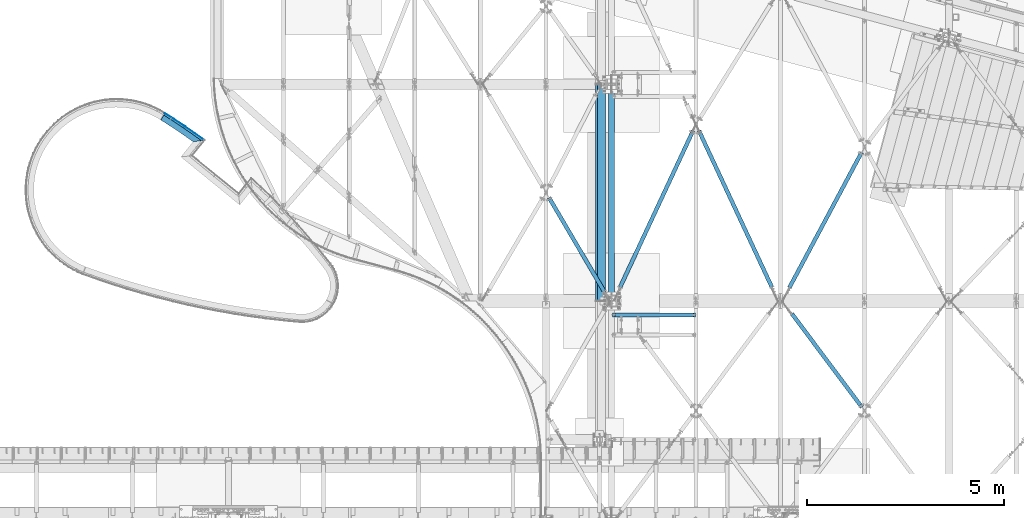
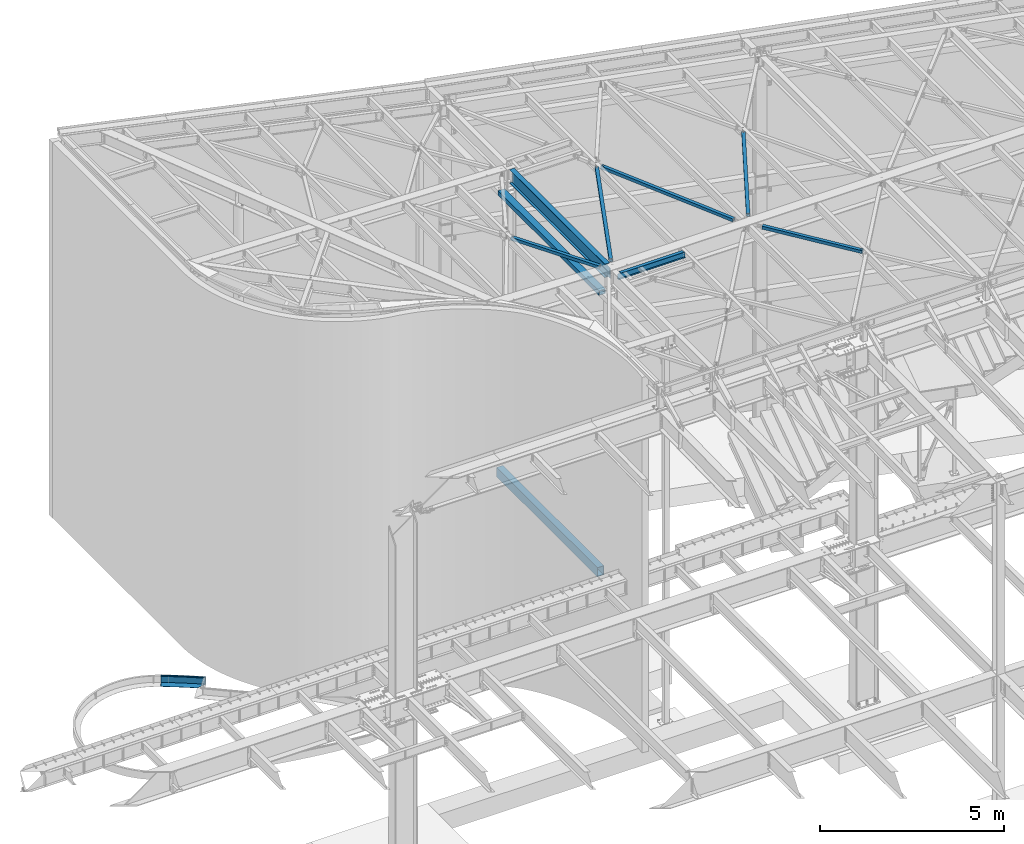
# One storey, part 1152 of 1763: 12 beams, 10 elements without a shape of their own.
"""IFC2X3 building model written with IfcOpenShell, lengths in millimetres."""

from ifc_helpers import new_model, si_unit, frame, origin_with_axes, place, context, subcontext, project, spatial, faceted_brep, material, type_object, element, aggregate, save


model = new_model("IFC2X3")

# Units and contexts
model_context = context("Model", 3, precision=1e-05, world=origin_with_axes())
body_context = subcontext(model_context, "Body", "Model", "MODEL_VIEW")
ifc_project = project(units=[si_unit("LENGTHUNIT", "METRE", prefix="MILLI"), si_unit("AREAUNIT", "SQUARE_METRE"), si_unit("VOLUMEUNIT", "CUBIC_METRE"), si_unit("MASSUNIT", "GRAM", prefix="KILO"), si_unit("TIMEUNIT", "SECOND"), si_unit("PLANEANGLEUNIT", "RADIAN"), si_unit("SOLIDANGLEUNIT", "STERADIAN"), si_unit("THERMODYNAMICTEMPERATUREUNIT", "DEGREE_CELSIUS"), si_unit("LUMINOUSINTENSITYUNIT", "LUMEN")], contexts=[model_context])

# Site, building, storey
site_placement = place(None, origin_with_axes())
site = spatial("IfcSite", under=ifc_project, at=site_placement, CompositionType="ELEMENT")
building_placement = place(site_placement, origin_with_axes())
building = spatial("IfcBuilding", under=site, at=building_placement, Name="Undefined", CompositionType="ELEMENT")
storey_placement = place(building_placement, origin_with_axes())
storey = spatial("IfcBuildingStorey", under=building, at=storey_placement, Name="Undefined", CompositionType="ELEMENT", Elevation=0.0)

# Assembly, beams
assembly_1_placement = place(storey_placement, origin_with_axes())
assembly_1 = element("IfcElementAssembly", 1, at=assembly_1_placement, inside=storey, Name="PLATE", AssemblyPlace="NOTDEFINED", PredefinedType="RIGID_FRAME")
ifc_material_1 = material(Name="STEEL/A36")
beam_type_1 = type_object("IfcBeamType", PredefinedType="NOTDEFINED")
beam_1_placement = place(assembly_1_placement, frame((-51077.3784696731, 62383.7207744882, -250.825), z_axis=(0.547466988136322, 0.836827280208374, 0.0), x_axis=(0.836827280208373, -0.547466988136323, 0.0)))
beam_1 = element("IfcBeam", 2, at=beam_1_placement, type_object=beam_type_1, material=ifc_material_1, Name="PLATE", context=body_context, shape_type="Brep", body=[
    faceted_brep([(10.0865417062741, -3.17500008743065, -98.3292617559418), (6.35000010509975, -3.17500000000001, 98.4852721513162), (4.17785486206412e-08, 7.03514331235056e-08, 98.425000000243), (3.73654162029561, -5.10336519710108e-08, -98.3895339072369), (306.165417216951, -3.17500000000001, 101.331023322218), (612.330834247987, -3.17500000000001, 98.4249848149957), (612.330834247987, 3.17500000000001, 98.4249848149957), (306.165417216951, 3.17500000000001, 101.331023322218), (910.914176975595, 3.17500000000001, -107.000216220062), (608.594282907827, 3.17500000000001, -98.389548907151), (306.165412335249, 3.17500000000001, -95.5189766782496), (3.73654162029561, 3.17500000000001, -98.3895339072369), (4.17785486206412e-08, 3.17500000000001, 98.425000000243), (918.3859283559, 3.17500000000001, 89.7079316322706), (1217.57690494547, 3.17500000000001, 75.4985236143766), (1000.12444440338, 3.17500000000001, -111.237058867246), (918.3859283559, -3.17500000000001, 89.7079316322706), (1217.57690494547, -3.17500000000001, 75.4985236143766), (1000.12444440338, -3.17500000000001, -111.237058867246), (910.914176975595, -3.17500000000001, -107.000216220062), (608.594282907827, -3.17500000000001, -98.389548907151), (306.165412335249, -3.17500000000001, -95.5189766782496)], [[[0, 1, 2, 3]], [[4, 5, 6, 7]], [[8, 9, 10, 11, 12, 7, 6, 13, 14, 15]], [[5, 16, 13, 6]], [[13, 16, 17, 14]], [[15, 14, 17, 18]], [[19, 8, 15, 18]], [[9, 8, 19, 20]], [[10, 9, 20, 21]], [[11, 10, 21, 0, 3]], [[12, 11, 3, 2]], [[4, 7, 12, 2, 1]], [[21, 20, 19, 18, 17, 16, 5, 4, 1, 0]]]),
])
beam_type_2 = type_object("IfcBeamType", PredefinedType="NOTDEFINED")
beam_2_placement = place(assembly_1_placement, frame((-51021.8582786004, 62468.8080613474, -130.175), z_axis=(0.0, 0.0, 1.0), x_axis=(0.836819061160634, -0.547479551105094, 0.0)))
beam_2 = element("IfcBeam", 3, at=beam_2_placement, type_object=beam_type_2, material=ifc_material_1, Name="PLATE", context=body_context, shape_type="Brep", body=[
    faceted_brep([(6.47143222697196, -3.11361448790922, 123.825), (0.0602430581202498, 0.000571752359974198, 123.825), (0.0602430581202498, 0.000571752359974198, -123.825), (6.47143208340276, -3.11359935612199, -123.825), (-9.89530235528946e-10, 3.17499999998108, -123.825), (-9.89530235528946e-10, 3.17499999998108, 123.825), (306.286084533931, 6.08102800932829, 123.825), (306.286084533931, 6.08102800932829, -123.825), (612.572169099585, 3.17500324017601, 123.825), (612.572169099585, 3.17500324017601, -123.825), (918.747974716418, -5.54202798683036, 123.825), (918.747974716418, -5.54202798683036, -123.825), (1224.703262111, -20.066927085416, 123.825), (1224.703262111, -20.066927085416, -123.825), (1217.68876182109, -26.0907867926398, -123.825), (1217.68876182109, -26.0907867926398, 123.825), (918.50704594914, -11.8874557367089, 123.825), (918.50704594914, -11.8874557367089, -123.825), (612.451683042105, -3.17385359468972, -123.825), (612.451683042105, -3.17385359468972, 123.825), (306.286084567517, -0.2689719906557, -123.825), (306.286084567517, -0.2689719906557, 123.825)], [[[0, 1, 2, 3]], [[4, 5, 6, 7]], [[6, 8, 9, 7]], [[8, 10, 11, 9]], [[11, 10, 12, 13]], [[14, 13, 12, 15]], [[16, 17, 14, 15]], [[18, 17, 16, 19]], [[20, 18, 19, 21]], [[20, 21, 0, 3]], [[4, 7, 9, 11, 13, 14, 17, 18, 20, 3, 2]], [[5, 4, 2, 1]], [[21, 19, 16, 15, 12, 10, 8, 6, 5, 1, 0]]]),
])
beam_type_3 = type_object("IfcBeamType", PredefinedType="NOTDEFINED")
beam_3_placement = place(assembly_1_placement, frame((-51035.7642591912, 62447.5528571891, -3.175), z_axis=(0.547479551105092, 0.836819061160635, 0.0), x_axis=(0.836819061160634, -0.547479551105094, 0.0)))
beam_3 = element("IfcBeam", 4, at=beam_3_placement, type_object=beam_type_3, material=ifc_material_1, Name="PLATE", context=body_context, shape_type="Brep", body=[
    faceted_brep([(7.43646361827268, 3.17500008958277, -28.5044431845636), (1.08437511292868, -1.43714595779443e-09, -28.5647115024767), (-8.84756445884705e-09, 9.69761293490023e-09, 28.5749999999134), (6.35080316626409, 3.175, 28.6352561226777), (611.487794574437, 3.175, -28.5647082737523), (916.579615803115, 3.175, -37.2508777357652), (916.579615803115, -3.175, -37.2508777357652), (611.487794574437, -3.175, -28.5647082737523), (1161.57250206512, 3.175, -48.8816522294146), (1161.57250206512, -3.175, -48.8816522294146), (306.286084526073, -3.175, 31.481028009257), (612.572169091756, -3.175, 28.575003240112), (612.572169091756, 3.175, 28.575003240112), (306.286084526073, 3.175, 31.481028009257), (918.747974708574, -3.175, 19.857972013102), (918.747974708574, 3.175, 19.857972013102), (1224.70326210315, -3.175, 5.33307291452002), (1224.70326210315, 3.175, 5.33307291452002), (-8.84756445884705e-09, -3.175, 28.5749999999134), (1.08437511292868, -3.175, -28.5647115024767), (306.286084828374, -3.175, -25.6689719905771), (306.286084828374, 3.175, -25.6689719905771)], [[[0, 1, 2, 3]], [[4, 5, 6, 7]], [[6, 5, 8, 9]], [[10, 11, 12, 13]], [[11, 14, 15, 12]], [[15, 14, 16, 17]], [[8, 17, 16, 9]], [[14, 11, 10, 18, 19, 20, 7, 6, 9, 16]], [[21, 4, 7, 20]], [[13, 12, 15, 17, 8, 5, 4, 21, 0, 3]], [[18, 10, 13, 3, 2]], [[19, 18, 2, 1]], [[21, 20, 19, 1, 0]]]),
])
aggregate(assembly_1, [beam_1, beam_2, beam_3])

# Assembly, beam
assembly_2_placement = place(storey_placement, origin_with_axes())
assembly_2 = element("IfcElementAssembly", 5, at=assembly_2_placement, inside=storey, Name="BEAM", AssemblyPlace="NOTDEFINED", PredefinedType="RIGID_FRAME")
ifc_material_2 = material(Name="STEEL/A992")
beam_type_4 = type_object("IfcBeamType", Name="W8X10", PredefinedType="NOTDEFINED")
beam_4_placement = place(assembly_2_placement, frame((-39672.2896174484, 57346.8499999993, 12345.9875), z_axis=(0.0, 0.0, 1.0), x_axis=(1.0, 0.0, 0.0)))
beam_4 = element("IfcBeam", 6, at=beam_4_placement, type_object=beam_type_4, material=ifc_material_2, Name="BEAM", ObjectType="W8X10", context=body_context, shape_type="Brep", body=[
    faceted_brep([(2073.27499999999, -50.8000000000029, 100.012500000001), (2073.27499999999, -50.8000000000029, 95.25), (2073.27499999999, -2.38124999999854, 95.25), (2073.27499999999, -2.38124999999854, 93.4024995803829), (2073.27499999999, 2.38124999999854, 93.4024995803829), (2073.27499999999, 2.38124999999854, 95.25), (2073.27499999999, 50.8000000000029, 95.25), (2073.27499999999, 50.8000000000029, 100.012500000001), (2074.24172992259, -2.38124999999854, 88.5424200623365), (2074.24172992259, 2.38124999999854, 88.5424200623365), (2076.99474382306, -2.38124999999854, 84.4222435941829), (2076.99474382306, 2.38124999999854, 84.4222435941829), (2081.11492029121, -2.38124999999854, 81.6692296937053), (2081.11492029121, 2.38124999999854, 81.6692296937053), (2085.97499980926, -2.38124999999854, 80.7024997711178), (2085.97499980926, 2.38124999999854, 80.7024997711178), (2124.075, -2.38124999999854, 80.7024997711178), (2124.075, 2.38124999999854, 80.7024997711178), (88.8999969557553, -50.8000000000029, 100.012500000001), (88.8999969557553, 50.8000000000029, 100.012500000001), (88.8999969557553, 50.8000000000029, 95.25), (88.8999969557553, 2.38124999999854, 95.25), (88.8999969557553, 2.38124999999854, 84.1374998092651), (88.8999969557553, -2.38124999999854, 84.1374998092651), (88.8999969557553, -2.38124999999854, 95.25), (88.8999969557553, -50.8000000000029, 95.25), (87.9332670331642, 2.38124999999854, 79.2774202912187), (87.9332670331642, -2.38124999999854, 79.2774202912187), (85.1802531326903, 2.38124999999854, 75.1572438230651), (85.1802531326903, -2.38124999999854, 75.1572438230651), (81.0600766645366, 2.38124999999854, 72.4042299225875), (81.0600766645366, -2.38124999999854, 72.4042299225875), (76.1999971464902, 2.38124999999854, 71.4375), (76.1999971464902, -2.38124999999854, 71.4375), (16.6687500075204, 2.38124999999854, 71.4375), (16.6687500075204, -2.38124999999854, 71.4375), (16.6687500075204, 2.38124999999854, -95.25), (16.6687500075204, 50.8000000000029, -95.25), (16.6687500075204, 50.8000000000029, -100.012500000001), (16.6687500075204, -50.8000000000029, -100.012500000001), (16.6687500075204, -50.8000000000029, -95.25), (16.6687500075204, -2.38124999999854, -95.25), (2124.075, 2.38124999999854, -95.25), (2124.075, 50.8000000000029, -95.25), (2124.075, 50.8000000000029, -100.012500000001), (2124.075, -50.8000000000029, -100.012500000001), (2124.075, -50.8000000000029, -95.25), (2124.075, -2.38124999999854, -95.25)], [[[0, 1, 2, 3, 4, 5, 6, 7]], [[8, 9, 4, 3]], [[10, 11, 9, 8]], [[12, 13, 11, 10]], [[14, 15, 13, 12]], [[16, 17, 15, 14]], [[18, 19, 20, 21, 22, 23, 24, 25]], [[23, 22, 26, 27]], [[27, 26, 28, 29]], [[29, 28, 30, 31]], [[31, 30, 32, 33]], [[33, 32, 34, 35]], [[36, 37, 38, 39, 40, 41, 35, 34]], [[37, 36, 42, 43]], [[38, 37, 43, 44]], [[39, 38, 44, 45]], [[40, 39, 45, 46]], [[41, 40, 46, 47]], [[12, 10, 8, 3, 2, 24, 23, 27, 29, 31, 33, 35, 41, 47, 16, 14]], [[25, 24, 2, 1]], [[18, 25, 1, 0]], [[19, 18, 0, 7]], [[20, 19, 7, 6]], [[21, 20, 6, 5]], [[42, 36, 34, 32, 30, 28, 26, 22, 21, 5, 4, 9, 11, 13, 15, 17]], [[47, 46, 45, 44, 43, 42, 17, 16]]]),
])
aggregate(assembly_2, [beam_4])

assembly_3_placement = place(storey_placement, origin_with_axes())
assembly_3 = element("IfcElementAssembly", 7, at=assembly_3_placement, inside=storey, Name="H. BRACE", AssemblyPlace="NOTDEFINED", PredefinedType="RIGID_FRAME")
ifc_material_3 = material()
beam_type_5 = type_object("IfcBeamType", Name="HSS4X4X3/8", PredefinedType="NOTDEFINED")
beam_5_placement = place(assembly_3_placement, frame((-37532.339615497, 62183.5045135885, 12371.3875), z_axis=(0.0, 0.0, 1.0), x_axis=(-0.422551801085181, -0.906338775182696, 0.0)))
beam_5 = element("IfcBeam", 8, at=beam_5_placement, type_object=beam_type_5, material=ifc_material_3, Name="H. BRACE", ObjectType="HSS4X4X3/8", context=body_context, shape_type="Brep", body=[
    faceted_brep([(176.586661769732, 6.34999856256309, 50.7999999999993), (176.586661769732, 6.34999856256309, 41.2749999999996), (254.374161510495, 6.35000155575017, 41.2749999999996), (254.374161510495, 6.35000155575017, 50.7999999999993), (254.374161999192, -6.34999844434515, 50.7999999999993), (254.374161999192, -6.34999844434515, 41.2749999999996), (176.586661741341, -6.35000143753587, 41.2749999999996), (176.586661741341, -6.35000143753587, 50.7999999999993), (176.586661769732, 6.34999856256309, -41.2749999999996), (176.586661769732, 6.34999856256309, -50.7999999999993), (254.374161510495, 6.35000155575017, -50.7999999999993), (254.374161510495, 6.35000155575017, -41.2749999999996), (254.374161999192, -6.34999844434515, -41.2749999999996), (254.374161999192, -6.34999844434515, -50.7999999999993), (176.586661741341, -6.35000143753587, -50.7999999999993), (176.586661741341, -6.35000143753587, -41.2749999999996), (176.586661663285, -41.275000000097, -41.2749999999996), (176.586661663285, -41.275000000097, 41.2749999999996), (4557.63064918239, -41.2750000071683, 41.2749999999996), (4557.63064918239, -41.2750000071683, -41.2749999999996), (176.586661869078, 50.8000000002348, -50.7999999999993), (4557.63064918239, 50.7999999927488, -50.7999999999993), (4557.63064918239, -50.8000000071625, -50.7999999999993), (176.586661641981, -50.8000000001239, -50.7999999999993), (176.586661641981, -50.8000000001239, 50.7999999999993), (4557.63064918239, -50.8000000071625, 50.7999999999993), (176.586661847788, 41.275000000197, 41.2749999999996), (4557.63064918239, 41.2749999927546, 41.2749999999996), (176.586661847788, 41.275000000197, -41.2749999999996), (4557.63064918239, 41.2749999927546, -41.2749999999996), (4557.63064918239, 50.7999999927488, 50.7999999999993), (176.586661869078, 50.8000000002348, 50.7999999999993)], [[[0, 1, 2, 3]], [[4, 5, 6, 7]], [[3, 2, 5, 4]], [[8, 9, 10, 11]], [[12, 13, 14, 15]], [[11, 10, 13, 12]], [[16, 17, 18, 19]], [[9, 20, 21, 22, 23, 14, 13, 10]], [[24, 23, 22, 25]], [[17, 16, 15, 14, 23, 24, 7, 6]], [[1, 26, 27, 18, 17, 6, 5, 2]], [[26, 28, 29, 27]], [[25, 22, 21, 30], [18, 27, 29, 19]], [[20, 31, 30, 21]], [[24, 25, 30, 31, 0, 3, 4, 7]], [[31, 20, 9, 8, 28, 26, 1, 0]], [[16, 19, 29, 28, 8, 11, 12, 15]]]),
])
aggregate(assembly_3, [beam_5])

assembly_4_placement = place(storey_placement, origin_with_axes())
assembly_4 = element("IfcElementAssembly", 9, at=assembly_4_placement, inside=storey, Name="H. BRACE", AssemblyPlace="NOTDEFINED", PredefinedType="RIGID_FRAME")
beam_6_placement = place(assembly_4_placement, frame((-33252.4396174507, 54913.6789185365, 12371.3875), z_axis=(0.0, 0.0, 1.0), x_axis=(-0.599553898754952, 0.800334381672896, 0.0)))
beam_6 = element("IfcBeam", 10, at=beam_6_placement, type_object=beam_type_5, material=ifc_material_3, Name="H. BRACE", ObjectType="HSS4X4X3/8", context=body_context, shape_type="Brep", body=[
    faceted_brep([(115.472498353723, 6.31029747364482, 50.7999999999993), (115.472498353723, 6.31029747364482, 41.2749999999996), (192.682016704122, 6.3102970257587, 41.2749999999996), (192.682016704122, 6.3102970257587, 50.7999999999993), (192.682016630453, -6.38970297431115, 50.7999999999993), (192.682016630453, -6.38970297431115, 41.2749999999996), (115.472498353723, -6.38970252641411, 41.2749999999996), (115.472498353723, -6.38970252641411, 50.7999999999993), (115.472498353723, 6.31029747364482, -41.2749999999996), (115.472498353723, 6.31029747364482, -50.7999999999993), (192.682016704122, 6.3102970257587, -50.7999999999993), (192.682016704122, 6.3102970257587, -41.2749999999996), (192.682016630453, -6.38970297431115, -41.2749999999996), (192.682016630453, -6.38970297431115, -50.7999999999993), (115.472498353723, -6.38970252641411, -50.7999999999993), (115.472498353723, -6.38970252641411, -41.2749999999996), (115.472498353723, -41.2750000001415, -41.2749999999996), (115.472498353723, -41.2750000001415, 41.2749999999996), (3071.36045602318, -41.2750000018805, 41.2749999999996), (3071.36045602318, -41.2750000018805, -41.2749999999996), (115.472498353723, 50.8000000000084, -50.7999999999993), (3071.36045602318, 50.7999999982621, -50.7999999999993), (3071.36045602318, -50.8000000018892, -50.7999999999993), (115.472498353723, -50.8000000001466, -50.7999999999993), (115.472498353723, -50.8000000001466, 50.7999999999993), (3071.36045602318, -50.8000000018892, 50.7999999999993), (115.472498353723, 41.2749999999924, 41.2749999999996), (3071.36045602318, 41.2749999982461, 41.2749999999996), (115.472498353723, 41.2749999999924, -41.2749999999996), (3071.36045602318, 41.2749999982461, -41.2749999999996), (3071.36045602318, 50.7999999982621, 50.7999999999993), (115.472498353723, 50.8000000000084, 50.7999999999993)], [[[0, 1, 2, 3]], [[4, 5, 6, 7]], [[3, 2, 5, 4]], [[8, 9, 10, 11]], [[12, 13, 14, 15]], [[11, 10, 13, 12]], [[16, 17, 18, 19]], [[9, 20, 21, 22, 23, 14, 13, 10]], [[24, 23, 22, 25]], [[17, 16, 15, 14, 23, 24, 7, 6]], [[1, 26, 27, 18, 17, 6, 5, 2]], [[26, 28, 29, 27]], [[25, 22, 21, 30], [18, 27, 29, 19]], [[20, 31, 30, 21]], [[24, 25, 30, 31, 0, 3, 4, 7]], [[31, 20, 9, 8, 28, 26, 1, 0]], [[16, 19, 29, 28, 8, 11, 12, 15]]]),
])
aggregate(assembly_4, [beam_6])

assembly_5_placement = place(storey_placement, origin_with_axes())
assembly_5 = element("IfcElementAssembly", 11, at=assembly_5_placement, inside=storey, Name="H. BRACE", AssemblyPlace="NOTDEFINED", PredefinedType="RIGID_FRAME")
beam_7_placement = place(assembly_5_placement, frame((-39723.089617434, 57702.4500000121, 12371.3875), z_axis=(0.0, 0.0, 1.0), x_axis=(-0.50652204411247, 0.862227011191441, 0.0)))
beam_7 = element("IfcBeam", 12, at=beam_7_placement, type_object=beam_type_5, material=ifc_material_3, Name="H. BRACE", ObjectType="HSS4X4X3/8", context=body_context, shape_type="Brep", body=[
    faceted_brep([(3046.4073382124, 6.34999999966658, 50.7999999999993), (2968.54605253917, 6.34999999969568, 50.7999999999993), (2968.54605253917, 6.34999999969568, 41.2749999999996), (3046.4073382124, 6.34999999966658, 41.2749999999996), (2968.54605253917, -6.35000000015589, 50.7999999999993), (2968.54605253917, -6.35000000015589, 41.2749999999996), (3046.4073382124, -6.35000000018135, 50.7999999999993), (3046.4073382124, -6.35000000018135, 41.2749999999996), (3046.4073382124, 6.34999999966658, -41.2749999999996), (2968.54605253917, 6.34999999969568, -41.2749999999996), (2968.54605253917, 6.34999999969568, -50.7999999999993), (3046.4073382124, 6.34999999966658, -50.7999999999993), (2968.54605253917, -6.35000000015589, -41.2749999999996), (2968.54605253917, -6.35000000015589, -50.7999999999993), (3046.4073382124, -6.35000000018135, -41.2749999999996), (3046.4073382124, -6.35000000018135, -50.7999999999993), (285.489916551436, 41.2749999997386, 41.2749999999996), (285.489916551436, 41.2749999997386, -41.2749999999996), (3046.4073382124, 41.2749999987818, -41.2749999999996), (3046.4073382124, 41.2749999987818, 41.2749999999996), (3046.40733821242, -41.27500000089, 41.2749999999996), (285.489916551422, -41.2749999999369, 41.2749999999996), (285.489916551422, -41.2749999999369, -41.2749999999996), (3046.40733821242, -41.27500000089, -41.2749999999996), (285.489916551436, -50.799999999902, -50.7999999999993), (285.489916551436, -50.799999999902, 50.7999999999993), (285.489916551436, 50.7999999997037, 50.7999999999993), (285.489916551436, 50.7999999997037, -50.7999999999993), (3046.4073382124, 50.7999999987433, 50.7999999999993), (3046.4073382124, 50.7999999987433, -50.7999999999993), (3046.4073382124, -50.8000000008551, -50.7999999999993), (3046.4073382124, -50.8000000008551, 50.7999999999993)], [[[0, 1, 2, 3]], [[4, 5, 2, 1]], [[6, 7, 5, 4]], [[8, 9, 10, 11]], [[12, 13, 10, 9]], [[14, 15, 13, 12]], [[16, 17, 18, 19]], [[20, 21, 16, 19, 3, 2, 5, 7]], [[22, 21, 20, 23]], [[9, 8, 18, 17, 22, 23, 14, 12]], [[24, 25, 26, 27], [16, 21, 22, 17]], [[27, 26, 28, 29]], [[19, 18, 8, 11, 29, 28, 0, 3]], [[30, 24, 27, 29, 11, 10, 13, 15]], [[25, 24, 30, 31]], [[1, 0, 28, 26, 25, 31, 6, 4]], [[31, 30, 15, 14, 23, 20, 7, 6]]]),
])
aggregate(assembly_5, [beam_7])

assembly_6_placement = place(storey_placement, origin_with_axes())
assembly_6 = element("IfcElementAssembly", 13, at=assembly_6_placement, inside=storey, Name="H. BRACE", AssemblyPlace="NOTDEFINED", PredefinedType="RIGID_FRAME")
beam_8_placement = place(assembly_6_placement, frame((-35443.1896206415, 57702.4499982766, 12371.3875), z_axis=(0.0, 0.0, 1.0), x_axis=(-0.422551799059311, 0.906338776127194, 0.0)))
beam_8 = element("IfcBeam", 14, at=beam_8_placement, type_object=beam_type_5, material=ifc_material_3, Name="H. BRACE", ObjectType="HSS4X4X3/8", context=body_context, shape_type="Brep", body=[
    faceted_brep([(4767.54090615794, 6.34985843226696, 50.7999999999993), (4689.75341807072, 6.35000452451732, 50.7999999999993), (4689.75341807072, 6.35000452451732, 41.2749999999996), (4767.54090615794, 6.34985843226696, 41.2749999999996), (4689.75339421892, -6.3499954753961, 50.7999999999993), (4689.75339421892, -6.3499954753961, 41.2749999999996), (4767.54090615793, -6.35014156769739, 50.7999999999993), (4767.54090615794, -6.35014156769739, 41.2749999999996), (4767.54090615794, 6.34985843226696, -41.2749999999996), (4689.75341807072, 6.35000452451732, -41.2749999999996), (4689.75341807072, 6.35000452451732, -50.7999999999993), (4767.54090615794, 6.34985843226696, -50.7999999999993), (4689.75339421892, -6.3499954753961, -41.2749999999996), (4689.75339421892, -6.3499954753961, -50.7999999999993), (4767.54090615794, -6.35014156769739, -41.2749999999996), (4767.54090615793, -6.35014156769739, -50.7999999999993), (386.893859833945, 41.2749999988782, 41.2749999999996), (386.893859833945, 41.2749999988782, -41.2749999999996), (4767.54090615794, 41.2749999869202, -41.2749999999996), (4767.54090615794, 41.2749999869202, 41.2749999999996), (4767.54090615794, -41.2750000129663, 41.2749999999996), (386.893859833945, -41.275000001001, 41.2749999999996), (386.893859833945, -41.275000001001, -41.2749999999996), (4767.54090615794, -41.2750000129663, -41.2749999999996), (386.893859833945, -50.8000000009879, -50.7999999999993), (386.893859833945, -50.8000000009879, 50.7999999999993), (386.893859833945, 50.7999999988724, 50.7999999999993), (386.893859833945, 50.7999999988724, -50.7999999999993), (4767.54090615794, 50.7999999869107, 50.7999999999993), (4767.54090615794, 50.7999999869107, -50.7999999999993), (4767.54090615793, -50.8000000129568, -50.7999999999993), (4767.54090615793, -50.8000000129568, 50.7999999999993)], [[[0, 1, 2, 3]], [[4, 5, 2, 1]], [[6, 7, 5, 4]], [[8, 9, 10, 11]], [[12, 13, 10, 9]], [[14, 15, 13, 12]], [[16, 17, 18, 19]], [[20, 21, 16, 19, 3, 2, 5, 7]], [[22, 21, 20, 23]], [[9, 8, 18, 17, 22, 23, 14, 12]], [[24, 25, 26, 27], [16, 21, 22, 17]], [[27, 26, 28, 29]], [[19, 18, 8, 11, 29, 28, 0, 3]], [[30, 24, 27, 29, 11, 10, 13, 15]], [[25, 24, 30, 31]], [[1, 0, 28, 26, 25, 31, 6, 4]], [[31, 30, 15, 14, 23, 20, 7, 6]]]),
])
aggregate(assembly_6, [beam_8])

assembly_7_placement = place(storey_placement, origin_with_axes())
assembly_7 = element("IfcElementAssembly", 15, at=assembly_7_placement, inside=storey, Name="H. BRACE", AssemblyPlace="NOTDEFINED", PredefinedType="RIGID_FRAME")
beam_9_placement = place(assembly_7_placement, frame((-35341.5896174484, 57702.45, 12371.3875), z_axis=(0.0, 0.0, 1.0), x_axis=(0.471177909926772, 0.88203819486292, 0.0)))
beam_9 = element("IfcBeam", 16, at=beam_9_placement, type_object=beam_type_5, material=ifc_material_3, Name="H. BRACE", ObjectType="HSS4X4X3/8", context=body_context, shape_type="Brep", body=[
    faceted_brep([(4278.14526328527, 6.34999824551778, 50.7999999999993), (4200.74674255188, 6.34999997542036, 50.7999999999993), (4200.74674255188, 6.34999997542036, 41.2749999999996), (4278.14526328527, 6.34999824551778, 41.2749999999996), (4200.74674226802, -6.35000002459128, 50.7999999999993), (4200.74674226802, -6.35000002459128, 41.2749999999996), (4278.14526328526, -6.35000175449386, 50.7999999999993), (4278.14526328526, -6.35000175449386, 41.2749999999996), (4278.14526328527, 6.34999824551778, -41.2749999999996), (4200.74674255188, 6.34999997542036, -41.2749999999996), (4200.74674255188, 6.34999997542036, -50.7999999999993), (4278.14526328527, 6.34999824551778, -50.7999999999993), (4200.74674226802, -6.35000002459128, -41.2749999999996), (4200.74674226802, -6.35000002459128, -50.7999999999993), (4278.14526328526, -6.35000175449386, -41.2749999999996), (4278.14526328526, -6.35000175449386, -50.7999999999993), (387.114213726723, 41.2749999997104, 41.2749999999996), (387.114213726723, 41.2749999997104, -41.2749999999996), (4278.14526328526, 41.2749999958978, -41.2749999999996), (4278.14526328526, 41.2749999958978, 41.2749999999996), (4278.14526328526, -41.275000004287, 41.2749999999996), (387.114213726723, -41.2750000004598, 41.2749999999996), (387.114213726723, -41.2750000004598, -41.2749999999996), (4278.14526328526, -41.275000004287, -41.2749999999996), (387.114213726723, -50.8000000004904, -50.7999999999993), (387.114213726723, -50.8000000004904, 50.7999999999993), (387.114213726723, 50.7999999997337, 50.7999999999993), (387.114213726723, 50.7999999997337, -50.7999999999993), (4278.14526328526, 50.7999999959211, 50.7999999999993), (4278.14526328526, 50.7999999959211, -50.7999999999993), (4278.14526328526, -50.800000004303, -50.7999999999993), (4278.14526328526, -50.800000004303, 50.7999999999993)], [[[0, 1, 2, 3]], [[4, 5, 2, 1]], [[6, 7, 5, 4]], [[8, 9, 10, 11]], [[12, 13, 10, 9]], [[14, 15, 13, 12]], [[16, 17, 18, 19]], [[20, 21, 16, 19, 3, 2, 5, 7]], [[22, 21, 20, 23]], [[9, 8, 18, 17, 22, 23, 14, 12]], [[24, 25, 26, 27], [16, 21, 22, 17]], [[27, 26, 28, 29]], [[19, 18, 8, 11, 29, 28, 0, 3]], [[30, 24, 27, 29, 11, 10, 13, 15]], [[25, 24, 30, 31]], [[1, 0, 28, 26, 25, 31, 6, 4]], [[31, 30, 15, 14, 23, 20, 7, 6]]]),
])
aggregate(assembly_7, [beam_9])

assembly_8_placement = place(storey_placement, origin_with_axes())
assembly_8 = element("IfcElementAssembly", 17, at=assembly_8_placement, inside=storey, Name="BEAM", AssemblyPlace="NOTDEFINED", PredefinedType="RIGID_FRAME")
beam_type_6 = type_object("IfcBeamType", Name="W18X35", PredefinedType="NOTDEFINED")
beam_10_placement = place(assembly_8_placement, frame((-39672.2896174484, 57702.45, 12220.575), z_axis=(0.0, 0.0, 1.0), x_axis=(0.0, 1.0, 0.0)))
beam_10 = element("IfcBeam", 18, at=beam_10_placement, type_object=beam_type_6, material=ifc_material_2, Name="BEAM", ObjectType="W18X35", context=body_context, shape_type="Brep", body=[
    faceted_brep([(5354.6375, -76.1999999999971, 214.3125), (5354.6375, -76.1999999999971, 225.424999999999), (179.387499999961, -76.1999999999971, 225.424999999999), (179.387499999961, -76.1999999999971, 214.3125), (5354.6375, 76.1999999999971, 225.424999999999), (179.387499999961, 76.1999999999971, 225.424999999999), (5354.6375, 76.1999999999971, 214.3125), (179.387499999961, 76.1999999999971, 214.3125), (5354.6375, 3.96875, 214.3125), (179.387499999961, 3.96875, 214.3125), (166.687500190696, -3.96875, 174.365001678467), (166.687500190696, 3.96875, 174.365001678467), (20.6374999999971, 3.96875, 174.365001678467), (20.6374999999971, -3.96875, 174.365001678467), (171.547579708742, -3.96875, 175.331731601054), (171.547579708742, 3.96875, 175.331731601054), (175.667756176896, -3.96875, 178.084745501532), (175.667756176896, 3.96875, 178.084745501532), (178.42077007737, -3.96875, 182.204921969686), (178.42077007737, 3.96875, 182.204921969686), (179.387499999961, -3.96875, 187.065001487732), (179.387499999961, 3.96875, 187.065001487732), (179.387499999961, -3.96875, 214.3125), (5354.6375, -3.96875, 214.3125), (5354.6375, 3.96875, -214.3125), (5354.6375, -3.96875, -214.3125), (5354.6375, -76.1999999999971, -214.3125), (5354.6375, -76.1999999999971, -225.424999999999), (5354.6375, 76.1999999999971, -225.424999999999), (5354.6375, 76.1999999999971, -214.3125), (179.387499999961, -76.1999999999971, -214.3125), (179.387499999961, -76.1999999999971, -225.424999999999), (179.387499999961, 76.1999999999971, -225.424999999999), (179.387499999961, 76.1999999999971, -214.3125), (179.387499999961, 3.96875, -214.3125), (175.667756176896, 3.96875, -178.604743823065), (171.547579708742, 3.96875, -175.851729922588), (166.687500190696, 3.96875, -174.885), (20.6374999999971, 3.96875, -174.885), (179.387499999961, 3.96875, -187.584999809265), (178.42077007737, 3.96875, -182.724920291219), (20.6374999999971, -3.96875, -174.885), (166.687500190696, -3.96875, -174.885), (171.547579708742, -3.96875, -175.851729922588), (175.667756176896, -3.96875, -178.604743823065), (178.42077007737, -3.96875, -182.724920291219), (179.387499999961, -3.96875, -187.584999809265), (179.387499999961, -3.96875, -214.3125)], [[[0, 1, 2, 3]], [[1, 4, 5, 2]], [[4, 6, 7, 5]], [[6, 8, 9, 7]], [[10, 11, 12, 13]], [[14, 15, 11, 10]], [[16, 17, 15, 14]], [[18, 19, 17, 16]], [[20, 21, 19, 18]], [[2, 5, 7, 9, 21, 20, 22, 3]], [[23, 0, 3, 22]], [[24, 8, 6, 4, 1, 0, 23, 25, 26, 27, 28, 29]], [[27, 26, 30, 31]], [[28, 27, 31, 32]], [[29, 28, 32, 33]], [[24, 29, 33, 34]], [[35, 36, 37, 38, 12, 11, 15, 17, 19, 21, 9, 8, 24, 34, 39, 40]], [[13, 12, 38, 41]], [[25, 23, 22, 20, 18, 16, 14, 10, 13, 41, 42, 43, 44, 45, 46, 47]], [[26, 25, 47, 30]], [[46, 39, 34, 33, 32, 31, 30, 47]], [[45, 40, 39, 46]], [[44, 35, 40, 45]], [[43, 36, 35, 44]], [[42, 37, 36, 43]], [[41, 38, 37, 42]]]),
])
aggregate(assembly_8, [beam_10])

assembly_9_placement = place(storey_placement, origin_with_axes())
assembly_9 = element("IfcElementAssembly", 19, at=assembly_9_placement, inside=storey, Name="BEAM", AssemblyPlace="NOTDEFINED", PredefinedType="RIGID_FRAME")
beam_type_7 = type_object("IfcBeamType", Name="HSS8X6X3/8", PredefinedType="NOTDEFINED")
beam_11_placement = place(assembly_9_placement, frame((-39926.2896174484, 57702.45, 11684.0), z_axis=(-1.0, 0.0, 0.0), x_axis=(0.0, 1.0, 0.0)))
beam_11 = element("IfcBeam", 20, at=beam_11_placement, type_object=beam_type_7, material=ifc_material_3, Name="BEAM", ObjectType="HSS8X6X3/8", context=body_context, shape_type="Brep", body=[
    faceted_brep([(9.52500000000146, 66.6749999999993, -92.0749999999971), (9.52500000000146, -66.6749999999993, -92.0749999999971), (5489.575, -66.6749999999993, -92.0749999999971), (5489.575, 66.6749999999993, -92.0749999999971), (9.52500000000146, -66.6749999999993, 92.0749999999971), (5489.575, -66.6749999999993, 92.0749999999971), (9.52500000000146, 66.6749999999993, 92.0749999999971), (5489.575, 66.6749999999993, 92.0749999999971), (9.52500000000146, 76.2000000000007, -101.599999999999), (9.52500000000146, 76.2000000000007, 101.599999999999), (5489.575, 76.2000000000007, 101.599999999999), (5489.575, 76.2000000000007, -101.599999999999), (9.52500000000146, -76.2000000000007, 101.599999999999), (5489.575, -76.2000000000007, 101.599999999999), (9.52500000000146, -76.2000000000007, -101.599999999999), (5489.575, -76.2000000000007, -101.599999999999)], [[[0, 1, 2, 3]], [[1, 4, 5, 2]], [[4, 6, 7, 5]], [[6, 0, 3, 7]], [[8, 9, 10, 11]], [[9, 12, 13, 10]], [[12, 14, 15, 13]], [[14, 8, 11, 15]], [[13, 15, 11, 10], [5, 7, 3, 2]], [[14, 12, 9, 8], [6, 4, 1, 0]]]),
])
aggregate(assembly_9, [beam_11])

assembly_10_placement = place(storey_placement, origin_with_axes())
assembly_10 = element("IfcElementAssembly", 21, at=assembly_10_placement, inside=storey, Name="BEAM", AssemblyPlace="NOTDEFINED", PredefinedType="RIGID_FRAME")
beam_type_8 = type_object("IfcBeamType", Name="HSS12X8X3/8", PredefinedType="NOTDEFINED")
beam_12_placement = place(assembly_10_placement, frame((-39977.0896174484, 57702.45, 2451.1), z_axis=(0.0, 0.0, 1.0), x_axis=(0.0, 1.0, 0.0)))
beam_12 = element("IfcBeam", 22, at=beam_12_placement, type_object=beam_type_8, material=ifc_material_3, Name="BEAM", ObjectType="HSS12X8X3/8", context=body_context, shape_type="Brep", body=[
    faceted_brep([(9.52500000000146, 92.0749999999971, -142.875), (9.52500000000146, -92.0749999999971, -142.875), (5489.57499999998, -92.0749999999971, -142.875), (5489.57499999998, 92.0749999999971, -142.875), (9.52500000000146, -92.0749999999971, 142.875), (5489.57499999998, -92.0749999999971, 142.875), (9.52500000000146, 92.0749999999971, 142.875), (5489.57499999998, 92.0749999999971, 142.875), (9.52500000000146, 101.599999999999, -152.4), (9.52500000000146, 101.599999999999, 152.4), (5489.57499999998, 101.599999999999, 152.4), (5489.57499999998, 101.599999999999, -152.4), (9.52500000000146, -101.599999999999, 152.4), (5489.57499999998, -101.599999999999, 152.4), (9.52500000000146, -101.599999999999, -152.4), (5489.57499999998, -101.599999999999, -152.4)], [[[0, 1, 2, 3]], [[1, 4, 5, 2]], [[4, 6, 7, 5]], [[6, 0, 3, 7]], [[8, 9, 10, 11]], [[9, 12, 13, 10]], [[12, 14, 15, 13]], [[14, 8, 11, 15]], [[13, 15, 11, 10], [5, 7, 3, 2]], [[14, 12, 9, 8], [6, 4, 1, 0]]]),
])
aggregate(assembly_10, [beam_12])

save(model, "model.ifc")
